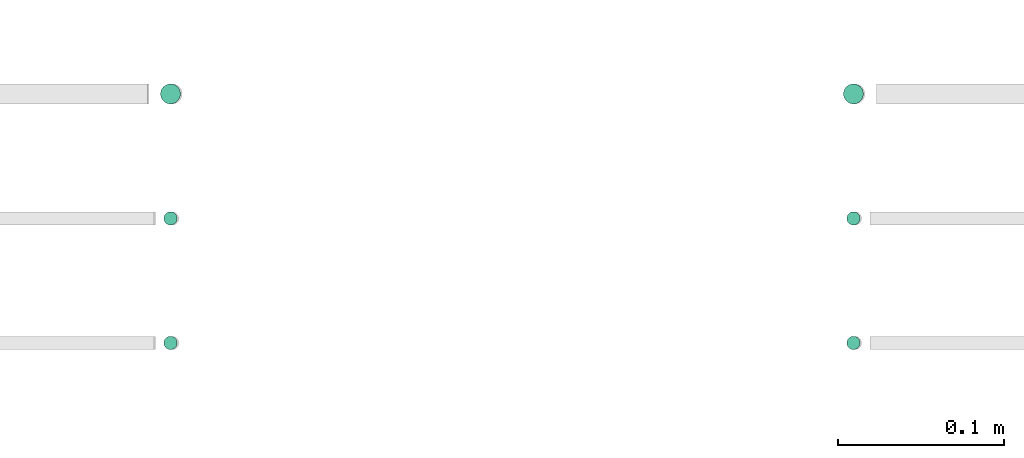
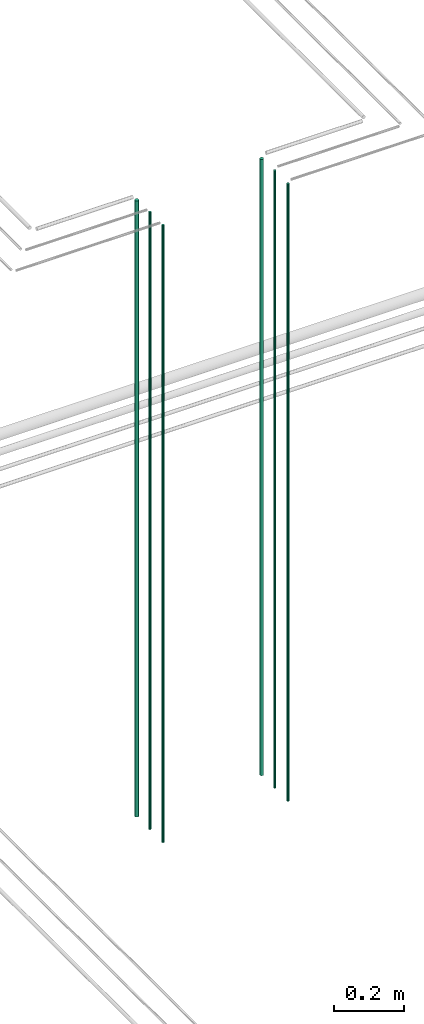
# One storey, part 40 of 331: 6 flow segments.
"""IFC2X3 building model written with IfcOpenShell, lengths in millimetres."""

from ifc_helpers import new_model, entity, si_unit, converted_unit, derived_unit, direction, frame, origin, origin_2d_with_axis, place, context, subcontext, project, spatial, circle, extrude, type_object, element, save


model = new_model("IFC2X3")

# Units and contexts
model_context = context("Model", 3, precision=0.01, world=origin(), true_north=direction((6.12303176911189e-17, 1.0)))
body_context = subcontext(model_context, "Body", "Model", "MODEL_VIEW")
ifc_project = project(units=[si_unit("LENGTHUNIT", "METRE", prefix="MILLI"), si_unit("AREAUNIT", "SQUARE_METRE"), si_unit("VOLUMEUNIT", "CUBIC_METRE"), converted_unit("PLANEANGLEUNIT", "DEGREE", entity("IfcRatioMeasure", 0.0174532925199433), si_unit("PLANEANGLEUNIT", "RADIAN"), dimensions=[0, 0, 0, 0, 0, 0, 0]), si_unit("MASSUNIT", "GRAM", prefix="KILO"), derived_unit("MASSDENSITYUNIT", [(si_unit("MASSUNIT", "GRAM", prefix="KILO"), 1), (si_unit("LENGTHUNIT", "METRE"), -3)]), derived_unit("MOMENTOFINERTIAUNIT", [(si_unit("LENGTHUNIT", "METRE"), 4)]), si_unit("TIMEUNIT", "SECOND"), si_unit("FREQUENCYUNIT", "HERTZ"), si_unit("THERMODYNAMICTEMPERATUREUNIT", "DEGREE_CELSIUS"), derived_unit("THERMALTRANSMITTANCEUNIT", [(si_unit("MASSUNIT", "GRAM", prefix="KILO"), 1), (si_unit("THERMODYNAMICTEMPERATUREUNIT", "KELVIN"), -1), (si_unit("TIMEUNIT", "SECOND"), -3)]), derived_unit("VOLUMETRICFLOWRATEUNIT", [(si_unit("LENGTHUNIT", "METRE"), 3), (si_unit("TIMEUNIT", "SECOND"), -1)]), derived_unit("MASSFLOWRATEUNIT", [(si_unit("MASSUNIT", "GRAM", prefix="KILO"), 1), (si_unit("TIMEUNIT", "SECOND"), -1)]), derived_unit("ROTATIONALFREQUENCYUNIT", [(si_unit("TIMEUNIT", "SECOND"), -1)]), si_unit("ELECTRICCURRENTUNIT", "AMPERE"), si_unit("ELECTRICVOLTAGEUNIT", "VOLT"), si_unit("POWERUNIT", "WATT"), si_unit("FORCEUNIT", "NEWTON", prefix="KILO"), si_unit("ILLUMINANCEUNIT", "LUX"), si_unit("LUMINOUSFLUXUNIT", "LUMEN"), si_unit("LUMINOUSINTENSITYUNIT", "CANDELA"), derived_unit("USERDEFINED", [(si_unit("MASSUNIT", "GRAM", prefix="KILO"), -1), (si_unit("LENGTHUNIT", "METRE"), -2), (si_unit("TIMEUNIT", "SECOND"), 3), (si_unit("LUMINOUSFLUXUNIT", "LUMEN"), 1)]), derived_unit("LINEARVELOCITYUNIT", [(si_unit("LENGTHUNIT", "METRE"), 1), (si_unit("TIMEUNIT", "SECOND"), -1)]), si_unit("PRESSUREUNIT", "PASCAL"), derived_unit("USERDEFINED", [(si_unit("LENGTHUNIT", "METRE"), -2), (si_unit("MASSUNIT", "GRAM", prefix="KILO"), 1), (si_unit("TIMEUNIT", "SECOND"), -2)]), derived_unit("LINEARFORCEUNIT", [(si_unit("MASSUNIT", "GRAM", prefix="KILO"), 1), (si_unit("LENGTHUNIT", "METRE"), 1), (si_unit("TIMEUNIT", "SECOND"), -2), (si_unit("LENGTHUNIT", "METRE"), -1)]), derived_unit("PLANARFORCEUNIT", [(si_unit("MASSUNIT", "GRAM", prefix="KILO"), 1), (si_unit("LENGTHUNIT", "METRE"), 1), (si_unit("TIMEUNIT", "SECOND"), -2), (si_unit("LENGTHUNIT", "METRE"), -2)])], contexts=[model_context])

# Site, building, storey
site_placement = place(None, frame((0.0, -0.00077364408347762, 0.0)))
site = spatial("IfcSite", under=ifc_project, at=site_placement, CompositionType="ELEMENT")
building_placement = place(site_placement, origin())
building = spatial("IfcBuilding", under=site, at=building_placement, CompositionType="ELEMENT")
storey_placement = place(building_placement, origin())
storey = spatial("IfcBuildingStorey", under=building, at=storey_placement, CompositionType="ELEMENT", Elevation=0.0)

# Flow segments
pipe_segment_type = type_object("IfcPipeSegmentType", PredefinedType="NOTDEFINED")
flow_segment_1_placement = place(storey_placement, frame((43956.8310109464, 1343.89349484378, 16890.0)))
element("IfcFlowSegment", 1, at=flow_segment_1_placement, inside=storey, type_object=pipe_segment_type, context=body_context, shape_type="SweptSolid", body=[
    extrude(circle(Radius=6.0, at=origin_2d_with_axis()), frame((7.59527223591454, 7.59527223591589, 0.0)), (0.0, 0.0, 1.0), 2146.0),
])
flow_segment_2_placement = place(storey_placement, frame((43958.8310109464, 1270.89349484379, 16890.0)))
element("IfcFlowSegment", 2, at=flow_segment_2_placement, inside=storey, type_object=pipe_segment_type, context=body_context, shape_type="SweptSolid", body=[
    extrude(circle(Radius=4.0, at=origin_2d_with_axis()), frame((5.59527223591499, 5.5952722359158, 0.0)), (0.0, 0.0, 1.0), 2150.00000000001),
])
flow_segment_3_placement = place(storey_placement, frame((43958.8310109464, 1195.89349484378, 16890.0)))
element("IfcFlowSegment", 3, at=flow_segment_3_placement, inside=storey, type_object=pipe_segment_type, context=body_context, shape_type="SweptSolid", body=[
    extrude(circle(Radius=4.0, at=origin_2d_with_axis()), frame((5.59527223591499, 5.59527223591607, 0.0)), (0.0, 0.0, 1.0), 2150.00000000001),
])
flow_segment_4_placement = place(storey_placement, frame((44368.1864417171, 1343.89349484378, 16890.0)))
element("IfcFlowSegment", 4, at=flow_segment_4_placement, inside=storey, type_object=pipe_segment_type, context=body_context, shape_type="SweptSolid", body=[
    extrude(circle(Radius=6.0, at=origin_2d_with_axis()), frame((7.59527223591454, 7.59527223591589, 0.0)), (0.0, 0.0, 1.0), 2146.0),
])
flow_segment_5_placement = place(storey_placement, frame((44370.186441717, 1270.89349484379, 16890.0)))
element("IfcFlowSegment", 5, at=flow_segment_5_placement, inside=storey, type_object=pipe_segment_type, context=body_context, shape_type="SweptSolid", body=[
    extrude(circle(Radius=4.0, at=origin_2d_with_axis()), frame((5.59527223591499, 5.5952722359158, 0.0)), (0.0, 0.0, 1.0), 2150.00000000001),
])
flow_segment_6_placement = place(storey_placement, frame((44370.186441717, 1195.89349484378, 16890.0)))
element("IfcFlowSegment", 6, at=flow_segment_6_placement, inside=storey, type_object=pipe_segment_type, context=body_context, shape_type="SweptSolid", body=[
    extrude(circle(Radius=4.0, at=origin_2d_with_axis()), frame((5.59527223591499, 5.59527223591607, 0.0)), (0.0, 0.0, 1.0), 2150.00000000001),
])

save(model, "model.ifc")
